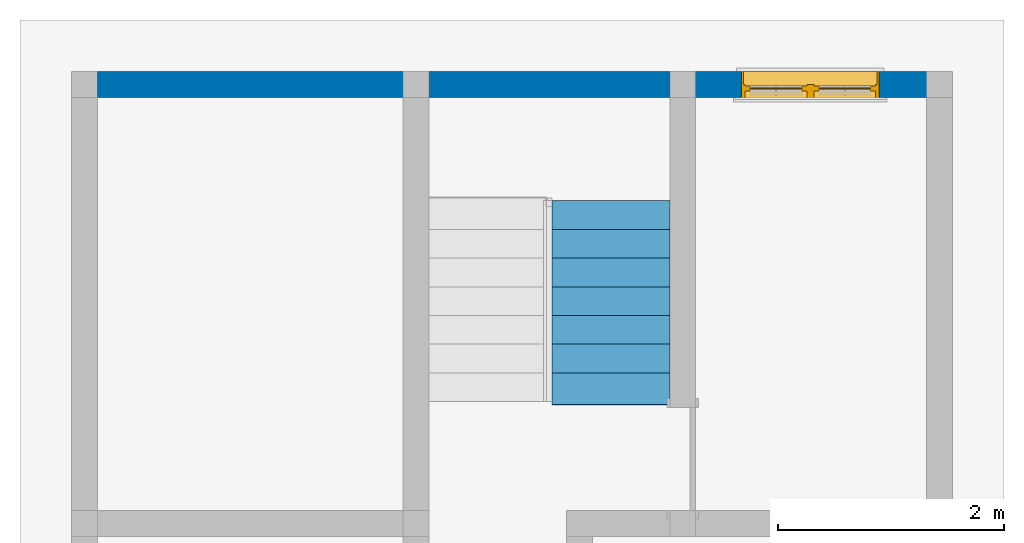
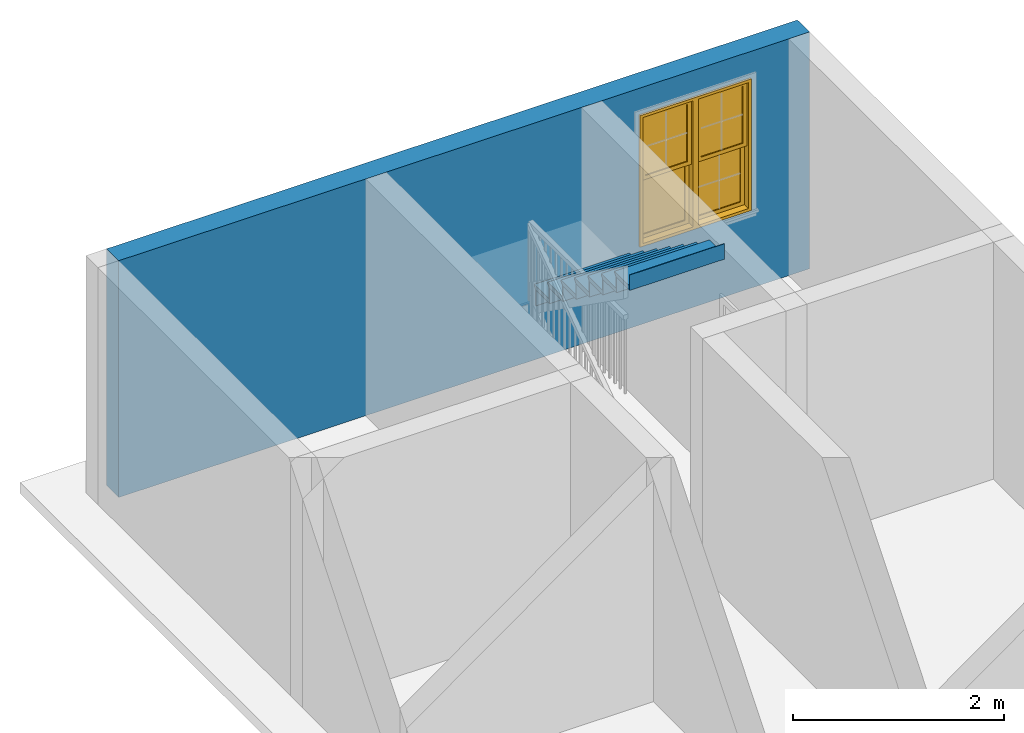
# One storey, part 3 of 6: 1 stair flight, 1 wall, 1 window, 1 opening, 1 element without a shape of its own.
"""IFC2X3 building model written with IfcOpenShell, lengths in feet."""

from ifc_helpers import new_model, entity, si_unit, converted_unit, derived_unit, direction, frame, frame_2d, origin, origin_2d_with_axis, place, context, subcontext, project, spatial, polyline, rectangle, outline, extrude, clip, bounded_halfspace, source, transform, mapped, material, material_list, layer, layer_set, layer_usage, type_object, type_shapes, element, fill, aggregate, save


model = new_model("IFC2X3")

# Units and contexts
model_context = context("Model", 3, precision=0.0001, world=origin(), true_north=direction((6.123031769111886e-17, 1.0)))
body_context = subcontext(model_context, "Body", "Model", "MODEL_VIEW")
ifc_project = project(units=[converted_unit("LENGTHUNIT", "FOOT", entity("IfcLengthMeasure", 0.3048), si_unit("LENGTHUNIT", "METRE"), dimensions=[1, 0, 0, 0, 0, 0, 0]), converted_unit("AREAUNIT", "SQUARE FOOT", entity("IfcAreaMeasure", 0.09290304), si_unit("AREAUNIT", "SQUARE_METRE"), dimensions=[2, 0, 0, 0, 0, 0, 0]), converted_unit("VOLUMEUNIT", "CUBIC FOOT", entity("IfcVolumeMeasure", 0.028316846592000004), si_unit("VOLUMEUNIT", "CUBIC_METRE"), dimensions=[3, 0, 0, 0, 0, 0, 0]), converted_unit("PLANEANGLEUNIT", "DEGREE", entity("IfcPlaneAngleMeasure", 0.017453292519943278), si_unit("PLANEANGLEUNIT", "RADIAN"), dimensions=[0, 0, 0, 0, 0, 0, 0]), si_unit("MASSUNIT", "GRAM", prefix="KILO"), derived_unit("MASSDENSITYUNIT", [(si_unit("MASSUNIT", "GRAM", prefix="KILO"), 1), (si_unit("LENGTHUNIT", "METRE"), -3)]), derived_unit("IONCONCENTRATIONUNIT", [(si_unit("MASSUNIT", "GRAM", prefix="KILO"), 1), (si_unit("LENGTHUNIT", "METRE"), -3)]), derived_unit("MOMENTOFINERTIAUNIT", [(si_unit("LENGTHUNIT", "METRE"), 4)]), si_unit("TIMEUNIT", "SECOND"), si_unit("FREQUENCYUNIT", "HERTZ"), si_unit("THERMODYNAMICTEMPERATUREUNIT", "DEGREE_CELSIUS"), derived_unit("THERMALTRANSMITTANCEUNIT", [(si_unit("MASSUNIT", "GRAM", prefix="KILO"), 1), (si_unit("THERMODYNAMICTEMPERATUREUNIT", "KELVIN"), -1), (si_unit("TIMEUNIT", "SECOND"), -3)]), derived_unit("THERMALCONDUCTANCEUNIT", [(si_unit("MASSUNIT", "GRAM", prefix="KILO"), 1), (si_unit("THERMODYNAMICTEMPERATUREUNIT", "KELVIN"), -1), (si_unit("TIMEUNIT", "SECOND"), -3), (si_unit("LENGTHUNIT", "METRE"), 1)]), derived_unit("VOLUMETRICFLOWRATEUNIT", [(si_unit("LENGTHUNIT", "METRE"), 3), (si_unit("TIMEUNIT", "SECOND"), -1)]), derived_unit("MASSFLOWRATEUNIT", [(si_unit("MASSUNIT", "GRAM", prefix="KILO"), 1), (si_unit("TIMEUNIT", "SECOND"), -1)]), derived_unit("ROTATIONALFREQUENCYUNIT", [(si_unit("TIMEUNIT", "SECOND"), -1)]), si_unit("ELECTRICCURRENTUNIT", "AMPERE"), si_unit("ELECTRICVOLTAGEUNIT", "VOLT"), si_unit("POWERUNIT", "WATT"), converted_unit("FORCEUNIT", "KIP", entity("IfcForceMeasure", 2.088543423315013e-05), si_unit("FORCEUNIT", "NEWTON"), dimensions=[1, 1, -2, 0, 0, 0, 0]), si_unit("ILLUMINANCEUNIT", "LUX"), si_unit("LUMINOUSFLUXUNIT", "LUMEN"), si_unit("LUMINOUSINTENSITYUNIT", "CANDELA"), si_unit("ENERGYUNIT", "JOULE"), derived_unit("USERDEFINED", [(si_unit("MASSUNIT", "GRAM", prefix="KILO"), -1), (si_unit("LENGTHUNIT", "METRE"), -2), (si_unit("TIMEUNIT", "SECOND"), 3), (si_unit("LUMINOUSFLUXUNIT", "LUMEN"), 1)]), derived_unit("USERDEFINED", [(si_unit("MASSUNIT", "GRAM", prefix="KILO"), 1), (si_unit("TIMEUNIT", "SECOND"), -3), (si_unit("LENGTHUNIT", "METRE"), 3), (si_unit("ELECTRICCURRENTUNIT", "AMPERE"), -2)]), derived_unit("SOUNDPOWERUNIT", [(si_unit("MASSUNIT", "GRAM", prefix="KILO"), 1), (si_unit("TIMEUNIT", "SECOND"), -3), (si_unit("LENGTHUNIT", "METRE"), 2)]), derived_unit("SOUNDPRESSUREUNIT", [(si_unit("MASSUNIT", "GRAM", prefix="KILO"), 1), (si_unit("LENGTHUNIT", "METRE"), -1), (si_unit("TIMEUNIT", "SECOND"), -2)]), derived_unit("LINEARVELOCITYUNIT", [(si_unit("LENGTHUNIT", "METRE"), 1), (si_unit("TIMEUNIT", "SECOND"), -1)]), si_unit("PRESSUREUNIT", "PASCAL"), derived_unit("USERDEFINED", [(si_unit("MASSUNIT", "GRAM", prefix="KILO"), 1), (si_unit("LENGTHUNIT", "METRE"), -2), (si_unit("TIMEUNIT", "SECOND"), -2)]), derived_unit("LINEARFORCEUNIT", [(si_unit("MASSUNIT", "GRAM", prefix="KILO"), 1), (si_unit("TIMEUNIT", "SECOND"), -2)]), derived_unit("PLANARFORCEUNIT", [(si_unit("MASSUNIT", "GRAM", prefix="KILO"), 1), (si_unit("LENGTHUNIT", "METRE"), -1), (si_unit("TIMEUNIT", "SECOND"), -2)]), derived_unit("SPECIFICHEATCAPACITYUNIT", [(si_unit("THERMODYNAMICTEMPERATUREUNIT", "KELVIN"), -1), (si_unit("LENGTHUNIT", "METRE"), 2), (si_unit("TIMEUNIT", "SECOND"), -2)]), derived_unit("HEATFLUXDENSITYUNIT", [(si_unit("MASSUNIT", "GRAM", prefix="KILO"), 1), (si_unit("TIMEUNIT", "SECOND"), -3)]), derived_unit("HEATINGVALUEUNIT", [(si_unit("LENGTHUNIT", "METRE"), 2), (si_unit("TIMEUNIT", "SECOND"), -2)]), derived_unit("VAPORPERMEABILITYUNIT", [(si_unit("LENGTHUNIT", "METRE"), -1), (si_unit("TIMEUNIT", "SECOND"), 1)]), derived_unit("DYNAMICVISCOSITYUNIT", [(si_unit("MASSUNIT", "GRAM", prefix="KILO"), 1), (si_unit("TIMEUNIT", "SECOND"), -1), (si_unit("LENGTHUNIT", "METRE"), -1)]), derived_unit("THERMALEXPANSIONCOEFFICIENTUNIT", [(si_unit("THERMODYNAMICTEMPERATUREUNIT", "KELVIN"), -1)]), derived_unit("MODULUSOFELASTICITYUNIT", [(si_unit("MASSUNIT", "GRAM", prefix="KILO"), 1), (si_unit("LENGTHUNIT", "METRE"), -1), (si_unit("TIMEUNIT", "SECOND"), -2)]), derived_unit("ISOTHERMALMOISTURECAPACITYUNIT", [(si_unit("LENGTHUNIT", "METRE"), 3), (si_unit("MASSUNIT", "GRAM", prefix="KILO"), -1)]), derived_unit("MOISTUREDIFFUSIVITYUNIT", [(si_unit("TIMEUNIT", "SECOND"), -1), (si_unit("LENGTHUNIT", "METRE"), 2)]), derived_unit("MASSPERLENGTHUNIT", [(si_unit("MASSUNIT", "GRAM", prefix="KILO"), 1), (si_unit("LENGTHUNIT", "METRE"), -1)]), derived_unit("THERMALRESISTANCEUNIT", [(si_unit("MASSUNIT", "GRAM", prefix="KILO"), -1), (si_unit("TIMEUNIT", "SECOND"), 3), (si_unit("THERMODYNAMICTEMPERATUREUNIT", "KELVIN"), 1)]), derived_unit("ACCELERATIONUNIT", [(si_unit("LENGTHUNIT", "METRE"), 1), (si_unit("TIMEUNIT", "SECOND"), -2)]), derived_unit("ANGULARVELOCITYUNIT", [(si_unit("TIMEUNIT", "SECOND"), -1), (si_unit("PLANEANGLEUNIT", "RADIAN"), 1)]), derived_unit("LINEARSTIFFNESSUNIT", [(si_unit("MASSUNIT", "GRAM", prefix="KILO"), 1), (si_unit("TIMEUNIT", "SECOND"), -2)]), derived_unit("WARPINGCONSTANTUNIT", [(si_unit("LENGTHUNIT", "METRE"), 6)]), derived_unit("LINEARMOMENTUNIT", [(si_unit("MASSUNIT", "GRAM", prefix="KILO"), 1), (si_unit("LENGTHUNIT", "METRE"), 1), (si_unit("TIMEUNIT", "SECOND"), -2)]), derived_unit("TORQUEUNIT", [(si_unit("MASSUNIT", "GRAM", prefix="KILO"), 1), (si_unit("LENGTHUNIT", "METRE"), 2), (si_unit("TIMEUNIT", "SECOND"), -2)])], contexts=[model_context])

# Site, building, storey
site_placement = place(None, origin())
site = spatial("IfcSite", under=ifc_project, at=site_placement, CompositionType="ELEMENT")
building_placement = place(site_placement, origin())
building = spatial("IfcBuilding", under=site, at=building_placement, CompositionType="ELEMENT")
storey_placement = place(building_placement, origin())
storey = spatial("IfcBuildingStorey", under=building, at=storey_placement, Name="Level 1", CompositionType="ELEMENT", Elevation=0.0)

# Wall, opening, window
ifc_material_1 = material(Name="Exterior Wall")
ifc_layer = layer(ifc_material_1, 0.75)
ifc_layer_set = layer_set([ifc_layer])
ifc_layer_usage = layer_usage(ifc_layer_set, "AXIS2", "NEGATIVE", 0.37500000000000006)
wall_type = type_object("IfcWallType", PredefinedType="STANDARD", material=ifc_layer_set)
wall_placement = place(storey_placement, frame((-16.159913085251162, 16.375580298071608, 0.0)))
wall = element("IfcWallStandardCase", 1, at=wall_placement, inside=storey, type_object=wall_type, material=ifc_layer_usage, context=body_context, shape_type="Clipping", body=[
    clip(extrude(rectangle(XDim=24.83333333333337, YDim=0.75, at=frame_2d((12.416666666666686, 0.0), x_axis=(-1.0, 0.0))), origin(), (0.0, 0.0, 1.0), 9.00000000000167), bounded_halfspace(frame((0.0, -0.375, 9.0), z_axis=(0.0, 0.0, -1.0), x_axis=(0.0, -1.0, 0.0)), True, frame((0.0, -0.375, 9.0)), polyline([(0.0, 0.0), (8.875000000000004, 0.0), (9.625000000000007, 0.0), (16.625, 0.0), (17.375, 0.0), (24.08333333333337, 0.0), (24.83333333333337, 0.0), (24.83333333333337, 0.75), (0.0, 0.75), (0.0, 0.0)]))),
])
opening_placement = place(wall_placement, frame((22.70833333333333, 0.37500000000005945, 3.0)))
opening = element("IfcOpeningElement", 2, at=opening_placement, cuts=wall, ObjectType="Opening", context=body_context, shape_type="SweptSolid", body=[
    extrude(rectangle(XDim=4.9999999999999885, YDim=3.999999999999999, at=frame_2d((2.4999999999999942, 2.0), x_axis=(-1.0, 0.0))), frame((0.0, 0.0, 0.0), z_axis=(0.0, -1.0, 0.0), x_axis=(0.0, 0.0, 1.0)), (0.0, 0.0, 1.0), 0.7500000000000001),
])
ifc_material_2 = material(Name="Wood - Stained")
ifc_material_3 = material(Name="Glass")
ifc_material_list = material_list([ifc_material_2, ifc_material_3])
window_style = type_object("IfcWindowStyle", ConstructionType="NOTDEFINED", OperationType="NOTDEFINED", ParameterTakesPrecedence=False, Sizeable=False, material=ifc_material_list)
shared_shape = source(origin(), body_context, "Body", "SweptSolid", [
    extrude(outline(polyline([(-2.499999999999994, -2.0), (2.4999999999999947, -2.0), (2.4999999999999947, 2.0), (-2.499999999999994, 2.0), (-2.499999999999994, -2.0)]), holes=[polyline([(-2.437499999999994, -1.9374999999999998), (-2.437499999999994, 1.9374999999999993), (2.4374999999999947, 1.9374999999999976), (2.4374999999999947, -1.9375), (-2.437499999999994, -1.9374999999999998)])]), frame((2.0, 0.0, 2.4999999999999947), z_axis=(0.0, 1.0, 0.0), x_axis=(0.0, 0.0, -1.0)), (0.0, 0.0, 1.0), 0.3749999999967303),
    extrude(outline(polyline([(-0.8984374999998123, -1.2343749999997335), (0.8984374999998125, -1.2343749999997335), (0.8984374999998123, 1.2343749999997362), (-0.8984374999998114, 1.2343749999997353), (-0.8984374999998123, -1.2343749999997335)]), holes=[polyline([(0.7526041666664792, -1.0885416666664005), (-0.752604166666479, -1.0885416666664005), (-0.7526041666664791, 1.0885416666664032), (0.7526041666664794, 1.0885416666664032), (0.7526041666664792, -1.0885416666664005)])]), frame((2.997395833333143, 0.5624999999999911, 3.6614583333330764), z_axis=(0.0, 1.0, 0.0), x_axis=(1.0, 0.0, 0.0)), (0.0, 0.0, 1.0), 0.1458333333333338),
    extrude(outline(polyline([(-0.8984374999998124, -1.2343749999999964), (0.8984374999998122, -1.2343749999999964), (0.8984374999998128, 1.2343749999999964), (-0.8984374999998135, 1.2343749999999964), (-0.8984374999998124, -1.2343749999999964)]), holes=[polyline([(0.752604166666478, -1.0885416666666625), (-0.7526041666664784, -1.0885416666666625), (-0.7526041666664787, 1.0885416666666616), (0.7526041666664782, 1.0885416666666616), (0.752604166666478, -1.0885416666666625)])]), frame((2.9973958333331425, 0.41666666666665203, 1.338541666666675), z_axis=(0.0, 1.0, 0.0), x_axis=(1.0, 0.0, 0.0)), (0.0, 0.0, 1.0), 0.1458333333333396),
    extrude(rectangle(XDim=1.5052083333329382, YDim=0.020833333333333315, at=frame_2d((0.0, -2.7755575615628914e-17), x_axis=(1.0, 0.0))), frame((2.997395833333133, 0.6562500000000007, 2.572916666666666), z_axis=(0.0, 0.0, 1.0), x_axis=(-1.0, 0.0, 0.0)), (0.0, 0.0, 1.0), 2.177083333332682),
    extrude(rectangle(XDim=0.020833333333333343, YDim=1.5052083333329382, at=frame_2d((-1.3877787807814457e-17, -5.551115123125783e-17), x_axis=(1.0, 0.0))), frame((2.997395833333133, 0.6145833333333341, 2.572916666666666), z_axis=(0.0, 0.0, 1.0), x_axis=(0.0, -1.0, 0.0)), (0.0, 0.0, 1.0), 2.177083333332682),
    extrude(rectangle(XDim=1.5052083333329382, YDim=0.020833333333333343, at=frame_2d((0.0, 1.3877787807814457e-17), x_axis=(1.0, 0.0))), frame((2.997395833333133, 0.5104166666666634, 0.25000000000001066), z_axis=(0.0, 0.0, 1.0), x_axis=(-1.0, 0.0, 0.0)), (0.0, 0.0, 1.0), 2.1770833333333224),
    extrude(rectangle(XDim=0.020833333333333315, YDim=1.5052083333329382, at=origin_2d_with_axis()), frame((2.997395833333133, 0.4687499999999968, 0.25000000000001066), z_axis=(0.0, 0.0, 1.0), x_axis=(0.0, -1.0, 0.0)), (0.0, 0.0, 1.0), 2.1770833333333224),
    extrude(outline(polyline([(-0.8984375000001612, -1.23437499999973), (0.8984375000001608, -1.23437499999973), (0.8984375000001618, 1.2343749999997318), (-0.898437500000161, 1.2343749999997318), (-0.8984375000001612, -1.23437499999973)]), holes=[polyline([(0.7526041666668268, -1.088541666666396), (-0.7526041666668275, -1.088541666666396), (-0.7526041666668271, 1.0885416666663978), (0.7526041666668268, 1.088541666666397), (0.7526041666668268, -1.088541666666396)])]), frame((1.0026041666664967, 0.5624999999999978, 3.6614583333330764), z_axis=(0.0, 1.0, 0.0), x_axis=(1.0, 0.0, 0.0)), (0.0, 0.0, 1.0), 0.14583333333333337),
    extrude(outline(polyline([(-0.898437500000167, -1.2343749999999982), (0.8984375000001674, -1.2343749999999982), (0.8984375000001668, 1.234374999999997), (-0.8984375000001665, 1.2343749999999982), (-0.898437500000167, -1.2343749999999982)]), holes=[polyline([(0.7526041666668333, -1.0885416666666643), (-0.752604166666833, -1.0885416666666643), (-0.752604166666833, 1.0885416666666647), (0.7526041666668337, 1.0885416666666639), (0.7526041666668333, -1.0885416666666643)])]), frame((1.002604166666496, 0.41666666666665825, 1.3385416666666758), z_axis=(0.0, 1.0, 0.0), x_axis=(1.0, 0.0, 0.0)), (0.0, 0.0, 1.0), 0.14583333333333956),
    extrude(rectangle(XDim=0.02083333333333326, YDim=1.505208333333663, at=origin_2d_with_axis()), frame((1.002604166666493, 0.6562500000000862, 2.572916666666666), z_axis=(0.0, 0.0, 1.0), x_axis=(0.0, -1.0, 0.0)), (0.0, 0.0, 1.0), 2.177083333332682),
    extrude(rectangle(XDim=1.505208333333663, YDim=0.020833333333333343, at=frame_2d((0.0, -1.3877787807814457e-17), x_axis=(1.0, 0.0))), frame((1.002604166666493, 0.6145833333332489, 2.572916666666666), z_axis=(0.0, 0.0, 1.0), x_axis=(-1.0, 0.0, 0.0)), (0.0, 0.0, 1.0), 2.177083333332682),
    extrude(rectangle(XDim=0.020833333333333356, YDim=1.5052083333336685, at=frame_2d((-6.938893903907228e-18, 1.1102230246251565e-16), x_axis=(1.0, 0.0))), frame((1.0026041666664953, 0.510416666666651, 0.2500000000000062), z_axis=(0.0, 0.0, 1.0), x_axis=(0.0, -1.0, 0.0)), (0.0, 0.0, 1.0), 2.177083333333327),
    extrude(rectangle(XDim=1.5052083333336685, YDim=0.020833333333333315, at=frame_2d((-1.1102230246251565e-16, -1.3877787807814457e-17), x_axis=(1.0, 0.0))), frame((1.0026041666664953, 0.46874999999998435, 0.2500000000000062), z_axis=(0.0, 0.0, 1.0), x_axis=(-1.0, 0.0, 0.0)), (0.0, 0.0, 1.0), 2.177083333333327),
    extrude(outline(polyline([(-2.4999999999999973, -2.0), (2.499999999999997, -2.0), (2.4999999999999973, 2.0), (-2.4999999999999973, 2.0), (-2.4999999999999973, -2.0)]), holes=[polyline([(2.395833333332953, 1.8958333333329571), (2.395833333332953, 0.0989583333333327), (-2.395833333332809, 0.09895833333333293), (-2.395833333332953, 1.8958333333329567), (2.395833333332953, 1.8958333333329571)]), polyline([(2.3958333333329525, -1.8958333333329567), (-2.395833333332953, -1.895833333332957), (-2.395833333332953, -0.09895833333333293), (2.3958333333333224, -0.09895833333333307), (2.3958333333329525, -1.8958333333329567)])]), frame((2.0, 0.3749999999999938, 2.4999999999999956), z_axis=(0.0, 1.0, 0.0), x_axis=(0.0, 0.0, -1.0)), (0.0, 0.0, 1.0), 0.4374999999999937),
])
type_shapes(window_style, [shared_shape])
window_placement = place(opening_placement, frame((0.0, 0.0, 0.0), z_axis=(0.0, 0.0, 1.0), x_axis=(-1.0, 0.0, 0.0)))
window = element("IfcWindow", 3, at=window_placement, inside=storey, type_object=window_style, material=ifc_material_list, OverallHeight=4.9999999999999885, OverallWidth=3.999999999999999, context=body_context, shape_type="MappedRepresentation", body=[
    mapped(shared_shape, transform((0.0, 0.0, 0.0), scale=1.0)),
])
fill(opening, window)

# Stair, stair flight
type_product = type_object("IfcTypeProduct")
stair_placement = place(storey_placement, origin())
stair = element("IfcStair", 4, at=stair_placement, inside=storey, type_object=type_product, Name="Assembled Stair:Stair", ShapeType="HALF_TURN_STAIR")
ifc_material_4 = material()
stair_flight_type = type_object("IfcStairFlightType", PredefinedType="STRAIGHT")
stair_flight_placement = place(stair_placement, origin())
stair_flight = element("IfcStairFlight", 5, at=stair_flight_placement, type_object=stair_flight_type, material=ifc_material_4, Name="Assembled Stair:Stair:385185 Run 2", NumberOfRiser=8, NumberOfTreads=7, RiserHeight=0.588541666666771, TreadLength=0.8333333333333334, context=body_context, shape_type="SweptSolid", body=[
    extrude(outline(polyline([(-0.09027777777777857, -0.5833333333333321), (0.0763888888888884, -0.5833333333333321), (0.0763888888888884, 0.2500000000000018), (0.05555555555555536, 0.2500000000000018), (-0.027777777777778567, 0.3333333333333357), (-0.09027777777777857, 0.3333333333333357), (-0.09027777777777857, -0.5833333333333321)])), frame((-2.9515797519178015, 12.667246964738325, 5.20659722222316), z_axis=(1.0, 0.0, 0.0), x_axis=(0.0, 0.0, -1.0)), (0.0, 0.0, 1.0), 3.416666666666666),
    extrude(rectangle(XDim=3.416666666666666, YDim=0.020833333333333925, at=frame_2d((1.1102230246251565e-16, 0.0), x_axis=(1.0, 0.0))), frame((-1.2432464185844676, 12.906830298071657, 4.541666666667501)), (0.0, 0.0, 1.0), 0.5885416666667709),
    extrude(rectangle(XDim=3.4166666666666665, YDim=0.020833333333333925, at=frame_2d((-1.1102230246251565e-16, -1.7763568394002505e-15), x_axis=(1.0, 0.0))), frame((-1.243246418584469, 12.073496964738325, 5.130208333334272)), (0.0, 0.0, 1.0), 0.5885416666667709),
    extrude(outline(polyline([(-0.09027777777777768, -0.5833333333333321), (0.07638888888888928, -0.5833333333333321), (0.07638888888888928, 0.25), (0.055555555555556246, 0.25), (-0.02777777777777768, 0.3333333333333339), (-0.09027777777777768, 0.3333333333333339), (-0.09027777777777768, -0.5833333333333321)])), frame((-2.951579751917802, 11.833913631404993, 5.795138888889932), z_axis=(1.0, 0.0, 0.0), x_axis=(0.0, 0.0, -1.0)), (0.0, 0.0, 1.0), 3.416666666666666),
    extrude(rectangle(XDim=3.4166666666666665, YDim=0.020833333333333925, at=frame_2d((-1.1102230246251565e-16, 0.0), x_axis=(1.0, 0.0))), frame((-1.2432464185844703, 11.240163631404991, 5.718750000001044)), (0.0, 0.0, 1.0), 0.5885416666667709),
    extrude(outline(polyline([(-0.09027777777777857, -0.5833333333333321), (0.0763888888888884, -0.5833333333333321), (0.0763888888888884, 0.25), (0.05555555555555536, 0.25), (-0.027777777777778567, 0.3333333333333339), (-0.09027777777777857, 0.3333333333333339), (-0.09027777777777857, -0.5833333333333321)])), frame((-2.9515797519178038, 11.000580298071661, 6.383680555556703), z_axis=(1.0, 0.0, 0.0), x_axis=(0.0, 0.0, -1.0)), (0.0, 0.0, 1.0), 3.416666666666666),
    extrude(rectangle(XDim=3.4166666666666665, YDim=0.020833333333333925, at=frame_2d((-1.1102230246251565e-16, 0.0), x_axis=(1.0, 0.0))), frame((-1.2432464185844716, 10.406830298071656, 6.3072916666678145)), (0.0, 0.0, 1.0), 0.5885416666667709),
    extrude(outline(polyline([(-0.09027777777777857, -0.5833333333333321), (0.0763888888888884, -0.5833333333333321), (0.0763888888888884, 0.25), (0.05555555555555536, 0.25), (-0.027777777777778567, 0.3333333333333339), (-0.09027777777777857, 0.3333333333333339), (-0.09027777777777857, -0.5833333333333321)])), frame((-2.951579751917805, 10.167246964738325, 6.972222222223474), z_axis=(1.0, 0.0, 0.0), x_axis=(0.0, 0.0, -1.0)), (0.0, 0.0, 1.0), 3.416666666666666),
    extrude(rectangle(XDim=3.4166666666666665, YDim=0.020833333333333925, at=frame_2d((-1.1102230246251565e-16, -1.7763568394002505e-15), x_axis=(1.0, 0.0))), frame((-1.243246418584473, 9.573496964738325, 6.895833333334585)), (0.0, 0.0, 1.0), 0.5885416666667709),
    extrude(outline(polyline([(-0.09027777777777857, -0.5833333333333321), (0.0763888888888884, -0.5833333333333321), (0.0763888888888884, 0.25), (0.05555555555555536, 0.25), (-0.027777777777778567, 0.3333333333333339), (-0.09027777777777857, 0.3333333333333339), (-0.09027777777777857, -0.5833333333333321)])), frame((-2.951579751917806, 9.333913631404993, 7.560763888890245), z_axis=(1.0, 0.0, 0.0), x_axis=(0.0, 0.0, -1.0)), (0.0, 0.0, 1.0), 3.416666666666666),
    extrude(rectangle(XDim=3.4166666666666665, YDim=0.020833333333333925, at=frame_2d((-1.1102230246251565e-16, 0.0), x_axis=(1.0, 0.0))), frame((-1.2432464185844743, 8.740163631404991, 7.484375000001357)), (0.0, 0.0, 1.0), 0.5885416666667709),
    extrude(outline(polyline([(-0.09027777777778034, -0.5833333333333313), (0.07638888888888751, -0.5833333333333313), (0.07638888888888751, 0.25), (0.05555555555555358, 0.25), (-0.027777777777780344, 0.3333333333333339), (-0.09027777777778034, 0.3333333333333339), (-0.09027777777778034, -0.5833333333333313)])), frame((-2.9515797519178073, 8.500580298071661, 8.149305555557016), z_axis=(1.0, 0.0, 0.0), x_axis=(0.0, 0.0, -1.0)), (0.0, 0.0, 1.0), 3.416666666666666),
    extrude(rectangle(XDim=3.4166666666666665, YDim=0.020833333333333925, at=frame_2d((-1.1102230246251565e-16, 0.0), x_axis=(1.0, 0.0))), frame((-1.2432464185844756, 7.906830298071657, 8.072916666668128)), (0.0, 0.0, 1.0), 0.5885416666667709),
    extrude(rectangle(XDim=3.4166666666666665, YDim=0.020833333333333037, at=frame_2d((-1.1102230246251565e-16, -4.440892098500626e-16), x_axis=(1.0, 0.0))), frame((-1.243246418584477, 7.073496964738324, 8.661458333334899)), (0.0, 0.0, 1.0), 0.5885416666667709),
    extrude(outline(polyline([(-0.09027777777778034, -0.5833333333333313), (0.07638888888888751, -0.5833333333333313), (0.07638888888888751, 0.25), (0.05555555555555358, 0.25), (-0.027777777777780344, 0.3333333333333339), (-0.09027777777778034, 0.3333333333333339), (-0.09027777777778034, -0.5833333333333313)])), frame((-2.951579751917809, 7.667246964738327, 8.737847222223786), z_axis=(1.0, 0.0, 0.0), x_axis=(0.0, 0.0, -1.0)), (0.0, 0.0, 1.0), 3.416666666666666),
])
aggregate(stair, [stair_flight])

save(model, "model.ifc")
